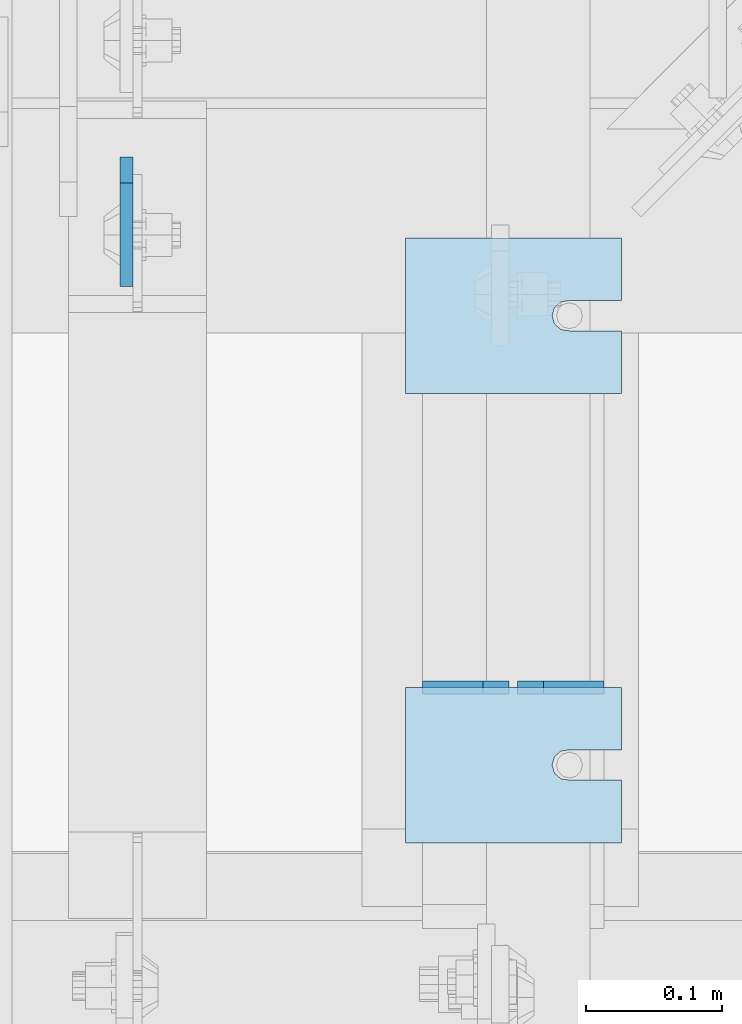
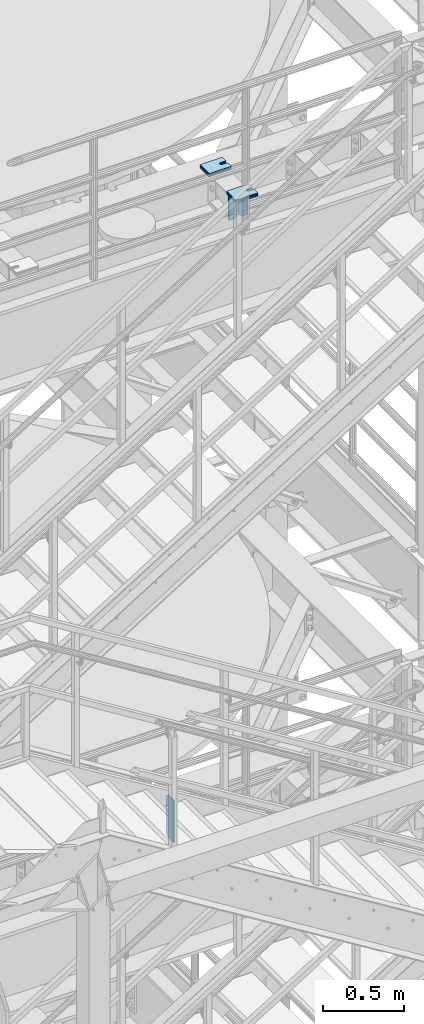
# One storey, part 1496 of 1876: 15 plates, 14 elements without a shape of their own.
"""IFC2X3 building model written with IfcOpenShell, lengths in millimetres."""

from ifc_helpers import new_model, si_unit, frame, origin_with_axes, place, context, subcontext, project, spatial, faceted_brep, material, type_object, element, aggregate, save


model = new_model("IFC2X3")

# Units and contexts
model_context = context("Model", 3, precision=1e-05, world=origin_with_axes())
body_context = subcontext(model_context, "Body", "Model", "MODEL_VIEW")
ifc_project = project(units=[si_unit("LENGTHUNIT", "METRE", prefix="MILLI"), si_unit("AREAUNIT", "SQUARE_METRE"), si_unit("VOLUMEUNIT", "CUBIC_METRE"), si_unit("MASSUNIT", "GRAM", prefix="KILO"), si_unit("TIMEUNIT", "SECOND"), si_unit("PLANEANGLEUNIT", "RADIAN"), si_unit("SOLIDANGLEUNIT", "STERADIAN"), si_unit("THERMODYNAMICTEMPERATUREUNIT", "DEGREE_CELSIUS"), si_unit("LUMINOUSINTENSITYUNIT", "LUMEN")], contexts=[model_context])

# Site, building, storey
site_placement = place(None, origin_with_axes())
site = spatial("IfcSite", under=ifc_project, at=site_placement, CompositionType="ELEMENT")
building_placement = place(site_placement, origin_with_axes())
building = spatial("IfcBuilding", under=site, at=building_placement, Name="Undefined", CompositionType="ELEMENT")
storey_placement = place(building_placement, origin_with_axes())
storey = spatial("IfcBuildingStorey", under=building, at=storey_placement, Name="Undefined", CompositionType="ELEMENT", Elevation=0.0)

# Assembly, plate
assembly_1_placement = place(storey_placement, origin_with_axes())
assembly_1 = element("IfcElementAssembly", 1, at=assembly_1_placement, inside=storey, Name="BEAM", AssemblyPlace="NOTDEFINED", PredefinedType="RIGID_FRAME")
ifc_material = material(Name="STEEL/A36")
plate_type_1 = type_object("IfcPlateType", PredefinedType="NOTDEFINED")
plate_1_placement = place(assembly_1_placement, frame((4919.66200006954, -3896.51875, 12977.8125), z_axis=(0.0, 0.0, 1.0), x_axis=(0.0, -1.0, 0.0)))
plate_1 = element("IfcPlate", 2, at=plate_1_placement, type_object=plate_type_1, material=ifc_material, Name="PLATE", context=body_context, shape_type="Brep", body=[
    faceted_brep([(0.0, -4.76249999999982, 19.0499992370605), (-1.81898940354586e-12, -4.76250000000073, 296.862499237061), (0.0, 4.76249999999982, 296.862499237061), (0.0, 4.76249999999982, 19.0499992370605), (19.0499992370605, -4.76249999999982, 315.912506103516), (19.0499992370605, 4.76249999999982, 315.912506103516), (95.25, -4.76249999999982, 315.912506103516), (95.25, 4.76249999999982, 315.912506103516), (95.25, -4.76249999999982, 0.0), (95.25, 4.76249999999982, 0.0), (19.0499992370605, -4.76249999999982, 0.0), (19.0499992370605, 4.76249999999982, 0.0)], [[[0, 1, 2, 3]], [[1, 4, 5, 2]], [[4, 6, 7, 5]], [[6, 8, 9, 7]], [[8, 10, 11, 9]], [[10, 0, 3, 11]], [[5, 7, 9, 11, 3, 2]], [[10, 8, 6, 4, 1, 0]]]),
])
aggregate(assembly_1, [plate_1])

# Assembly, plates
assembly_2_placement = place(storey_placement, origin_with_axes())
assembly_2 = element("IfcElementAssembly", 3, at=assembly_2_placement, inside=storey, Name="BEAM", AssemblyPlace="NOTDEFINED", PredefinedType="RIGID_FRAME")
plate_type_2 = type_object("IfcPlateType", PredefinedType="NOTDEFINED")
plate_2_placement = place(assembly_2_placement, frame((5270.5, -4286.24823280773, 17784.7625), z_axis=(0.0, 0.0, 1.0), x_axis=(-1.0, 0.0, 0.0)))
plate_2 = element("IfcPlate", 4, at=plate_2_placement, type_object=plate_type_2, material=ifc_material, Name="PLATE", context=body_context, shape_type="Brep", body=[
    faceted_brep([(0.0, -4.76249999999982, 0.0), (0.0, -4.76249999999982, 190.5), (0.0, 4.76249999999982, 190.5), (0.0, 4.76249999999982, 0.0), (44.4500007629395, -4.76249999999982, 190.5), (44.4500007629395, 4.76249999999982, 190.5), (63.5, -4.76249999999982, 171.450000762939), (63.5, 4.76249999999982, 171.450000762939), (63.5, -4.76249999999982, 19.0499992370605), (63.5, 4.76249999999982, 19.0499992370605), (44.4500007629395, -4.76249999999982, 0.0), (44.4500007629395, 4.76249999999982, 0.0)], [[[0, 1, 2, 3]], [[1, 4, 5, 2]], [[4, 6, 7, 5]], [[6, 8, 9, 7]], [[8, 10, 11, 9]], [[10, 0, 3, 11]], [[5, 7, 9, 11, 3, 2]], [[10, 8, 6, 4, 1, 0]]]),
])
plate_3_placement = place(assembly_2_placement, frame((5200.65, -4286.24823280773, 17784.7625), z_axis=(0.0, 0.0, 1.0), x_axis=(-1.0, 0.0, 0.0)))
plate_3 = element("IfcPlate", 5, at=plate_3_placement, type_object=plate_type_2, material=ifc_material, Name="PLATE", context=body_context, shape_type="Brep", body=[
    faceted_brep([(0.0, -4.76249999999982, 19.0499992370605), (0.0, -4.76249999999982, 171.450000762939), (0.0, 4.76249999999982, 171.450000762939), (0.0, 4.76249999999982, 19.0499992370605), (19.0499992370605, -4.76249999999982, 190.5), (19.0499992370605, 4.76249999999982, 190.5), (63.5, -4.76249999999982, 190.5), (63.5, 4.76249999999982, 190.5), (63.5, -4.76249999999982, 0.0), (63.5, 4.76249999999982, 0.0), (19.0499992370605, -4.76249999999982, 0.0), (19.0499992370605, 4.76249999999982, 0.0)], [[[0, 1, 2, 3]], [[1, 4, 5, 2]], [[4, 6, 7, 5]], [[6, 8, 9, 7]], [[8, 10, 11, 9]], [[10, 0, 3, 11]], [[5, 7, 9, 11, 3, 2]], [[10, 8, 6, 4, 1, 0]]]),
])
aggregate(assembly_2, [plate_2, plate_3])

# Assembly, plate
assembly_3_placement = place(storey_placement, origin_with_axes())
assembly_3 = element("IfcElementAssembly", 6, at=assembly_3_placement, inside=storey, Name="SHIM PLATE", AssemblyPlace="NOTDEFINED", PredefinedType="RIGID_FRAME")
plate_type_3 = type_object("IfcPlateType", PredefinedType="NOTDEFINED")
plate_4_placement = place(assembly_3_placement, frame((5124.44990071747, -4286.24823360147, 18009.3925), z_axis=(0.0, -1.0, 0.0), x_axis=(1.0, 0.0, 0.0)))
plate_4 = element("IfcPlate", 7, at=plate_4_placement, type_object=plate_type_3, material=ifc_material, Name="SHIM PLATE", context=body_context, shape_type="Brep", body=[
    faceted_brep([(158.750372340321, -0.793499999999767, 45.9159391237008), (158.750372340321, 0.793499999999767, 45.9159391237008), (120.639297339384, 0.793499999999767, 45.9151982062995), (120.639297339384, -0.793499999999767, 45.9151982062995), (114.427892427377, 0.793499999999767, 46.8593737589063), (114.427892427377, -0.793499999999767, 46.8593737589063), (109.699635978252, 0.793499999999767, 50.9965961854132), (109.699635978252, -0.793499999999767, 50.9965961854132), (107.939290344286, 0.793499999999767, 57.0276990450948), (107.939290344286, -0.793499999999767, 57.0276990450948), (109.699637497522, 0.793499999999767, 63.0588014613368), (109.699637497522, -0.793499999999767, 63.0588014613368), (114.427894988835, 0.793499999999767, 67.1960226967731), (114.427894988835, -0.793499999999767, 67.1960226967731), (120.639300138686, 0.793499999999767, 68.140196684697), (120.639300138686, -0.793499999999767, 68.140196684697), (158.750375307166, -0.793499999999767, 68.1409376021466), (158.750375307166, 0.793499999999767, 68.1409376021466), (158.750366210938, -0.793499999999767, 5.27506927028298e-11), (9.09494701772928e-13, -0.793499999999767, 0.0), (9.09494701772928e-13, 0.793499999999767, 0.0), (158.750366210938, 0.793499999999767, 5.27506927028298e-11), (1.97695580936852e-05, -0.793499999999767, 114.305328369142), (1.97695580936852e-05, 0.793499999999767, 114.305328369142), (158.750381469715, -0.793499999999767, 114.305328369159), (158.750381469715, 0.793499999999767, 114.305328369159)], [[[0, 1, 2, 3]], [[3, 2, 4, 5]], [[5, 4, 6, 7]], [[7, 6, 8, 9]], [[9, 8, 10, 11]], [[11, 10, 12, 13]], [[13, 12, 14, 15]], [[16, 15, 14, 17]], [[18, 19, 20, 21]], [[19, 22, 23, 20]], [[22, 24, 25, 23]], [[25, 24, 16, 17]], [[12, 10, 8, 6, 4, 2, 1, 21, 20, 23, 25, 17, 14]], [[18, 21, 1, 0]], [[24, 22, 19, 18, 0, 3, 5, 7, 9, 11, 13, 15, 16]]]),
])
aggregate(assembly_3, [plate_4])

assembly_4_placement = place(storey_placement, origin_with_axes())
assembly_4 = element("IfcElementAssembly", 8, at=assembly_4_placement, inside=storey, Name="SHIM PLATE", AssemblyPlace="NOTDEFINED", PredefinedType="RIGID_FRAME")
plate_5_placement = place(assembly_4_placement, frame((5124.44990071747, -3956.04803828897, 18009.3925), z_axis=(0.0, -1.0, 0.0), x_axis=(1.0, 0.0, 0.0)))
plate_5 = element("IfcPlate", 9, at=plate_5_placement, type_object=plate_type_3, material=ifc_material, Name="SHIM PLATE", context=body_context, shape_type="Brep", body=[
    faceted_brep([(158.750372340321, -0.793499999999767, 45.9159391237008), (158.750372340321, 0.793499999999767, 45.9159391237008), (120.639297339384, 0.793499999999767, 45.9151982062995), (120.639297339384, -0.793499999999767, 45.9151982062995), (114.427892427377, 0.793499999999767, 46.8593737589063), (114.427892427377, -0.793499999999767, 46.8593737589063), (109.699635978252, 0.793499999999767, 50.9965961854132), (109.699635978252, -0.793499999999767, 50.9965961854132), (107.939290344286, 0.793499999999767, 57.0276990450948), (107.939290344286, -0.793499999999767, 57.0276990450948), (109.699637497522, 0.793499999999767, 63.0588014613368), (109.699637497522, -0.793499999999767, 63.0588014613368), (114.427894988835, 0.793499999999767, 67.1960226967731), (114.427894988835, -0.793499999999767, 67.1960226967731), (120.639300138686, 0.793499999999767, 68.140196684697), (120.639300138686, -0.793499999999767, 68.140196684697), (158.750375307166, -0.793499999999767, 68.1409376021466), (158.750375307166, 0.793499999999767, 68.1409376021466), (158.750366210938, -0.793499999999767, 5.27506927028298e-11), (9.09494701772928e-13, -0.793499999999767, 0.0), (9.09494701772928e-13, 0.793499999999767, 0.0), (158.750366210938, 0.793499999999767, 5.27506927028298e-11), (1.97695580936852e-05, -0.793499999999767, 114.305328369142), (1.97695580936852e-05, 0.793499999999767, 114.305328369142), (158.750381469715, -0.793499999999767, 114.305328369159), (158.750381469715, 0.793499999999767, 114.305328369159)], [[[0, 1, 2, 3]], [[3, 2, 4, 5]], [[5, 4, 6, 7]], [[7, 6, 8, 9]], [[9, 8, 10, 11]], [[11, 10, 12, 13]], [[13, 12, 14, 15]], [[16, 15, 14, 17]], [[18, 19, 20, 21]], [[19, 22, 23, 20]], [[22, 24, 25, 23]], [[25, 24, 16, 17]], [[12, 10, 8, 6, 4, 2, 1, 21, 20, 23, 25, 17, 14]], [[18, 21, 1, 0]], [[24, 22, 19, 18, 0, 3, 5, 7, 9, 11, 13, 15, 16]]]),
])
aggregate(assembly_4, [plate_5])

assembly_5_placement = place(storey_placement, origin_with_axes())
assembly_5 = element("IfcElementAssembly", 10, at=assembly_5_placement, inside=storey, Name="SHIM PLATE", AssemblyPlace="NOTDEFINED", PredefinedType="RIGID_FRAME")
plate_type_4 = type_object("IfcPlateType", PredefinedType="NOTDEFINED")
plate_6_placement = place(assembly_5_placement, frame((5124.44990071747, -4286.24823360146, 18007.0115), z_axis=(0.0, -1.0, 0.0), x_axis=(1.0, 0.0, 0.0)))
plate_6 = element("IfcPlate", 11, at=plate_6_placement, type_object=plate_type_4, material=ifc_material, Name="SHIM PLATE", context=body_context, shape_type="Brep", body=[
    faceted_brep([(158.750372340321, -1.58750000000146, 45.9159391237008), (158.750372340321, 1.58750000000146, 45.9159391237008), (120.639297339383, 1.58750000000146, 45.9151982062995), (120.639297339383, -1.58750000000146, 45.9151982062995), (114.427892427376, 1.58750000000146, 46.8593737589063), (114.427892427376, -1.58750000000146, 46.8593737589063), (109.699635978252, 1.58750000000146, 50.9965961854132), (109.699635978252, -1.58750000000146, 50.9965961854132), (107.939290344285, 1.58750000000146, 57.0276990450948), (107.939290344285, -1.58750000000146, 57.0276990450948), (109.699637497522, 1.58750000000146, 63.0588014613368), (109.699637497522, -1.58750000000146, 63.0588014613368), (114.427894988834, 1.58750000000146, 67.1960226967731), (114.427894988834, -1.58750000000146, 67.1960226967731), (120.639300138685, 1.58750000000146, 68.140196684697), (120.639300138685, -1.58750000000146, 68.140196684697), (158.750375307166, -1.58750000000146, 68.1409376021466), (158.750375307166, 1.58750000000146, 68.1409376021466), (158.750366210938, -1.58750000000146, 5.27506927028298e-11), (9.09494701772928e-13, -1.58750000000146, 4.54747350886464e-13), (9.09494701772928e-13, 1.58750000000146, 4.54747350886464e-13), (158.750366210938, 1.58750000000146, 5.27506927028298e-11), (1.97695599126746e-05, -1.58750000000146, 114.305328369142), (1.97695599126746e-05, 1.58750000000146, 114.305328369142), (158.750381469715, -1.58750000000146, 114.305328369159), (158.750381469715, 1.58750000000146, 114.305328369159)], [[[0, 1, 2, 3]], [[3, 2, 4, 5]], [[5, 4, 6, 7]], [[7, 6, 8, 9]], [[9, 8, 10, 11]], [[11, 10, 12, 13]], [[13, 12, 14, 15]], [[16, 15, 14, 17]], [[18, 19, 20, 21]], [[19, 22, 23, 20]], [[22, 24, 25, 23]], [[25, 24, 16, 17]], [[12, 10, 8, 6, 4, 2, 1, 21, 20, 23, 25, 17, 14]], [[18, 21, 1, 0]], [[24, 22, 19, 18, 0, 3, 5, 7, 9, 11, 13, 15, 16]]]),
])
aggregate(assembly_5, [plate_6])

assembly_6_placement = place(storey_placement, origin_with_axes())
assembly_6 = element("IfcElementAssembly", 12, at=assembly_6_placement, inside=storey, Name="SHIM PLATE", AssemblyPlace="NOTDEFINED", PredefinedType="RIGID_FRAME")
plate_7_placement = place(assembly_6_placement, frame((5124.44990071747, -4286.24823360147, 18003.8365), z_axis=(0.0, -1.0, 0.0), x_axis=(1.0, 0.0, 0.0)))
plate_7 = element("IfcPlate", 13, at=plate_7_placement, type_object=plate_type_4, material=ifc_material, Name="SHIM PLATE", context=body_context, shape_type="Brep", body=[
    faceted_brep([(158.750372340321, -1.58750000000146, 45.9159391237008), (158.750372340321, 1.58750000000146, 45.9159391237008), (120.639297339383, 1.58750000000146, 45.9151982062995), (120.639297339383, -1.58750000000146, 45.9151982062995), (114.427892427376, 1.58750000000146, 46.8593737589063), (114.427892427376, -1.58750000000146, 46.8593737589063), (109.699635978252, 1.58750000000146, 50.9965961854132), (109.699635978252, -1.58750000000146, 50.9965961854132), (107.939290344285, 1.58750000000146, 57.0276990450948), (107.939290344285, -1.58750000000146, 57.0276990450948), (109.699637497522, 1.58750000000146, 63.0588014613368), (109.699637497522, -1.58750000000146, 63.0588014613368), (114.427894988834, 1.58750000000146, 67.1960226967731), (114.427894988834, -1.58750000000146, 67.1960226967731), (120.639300138685, 1.58750000000146, 68.140196684697), (120.639300138685, -1.58750000000146, 68.140196684697), (158.750375307166, -1.58750000000146, 68.1409376021466), (158.750375307166, 1.58750000000146, 68.1409376021466), (158.750366210938, -1.58750000000146, 5.27506927028298e-11), (9.09494701772928e-13, -1.58750000000146, 4.54747350886464e-13), (9.09494701772928e-13, 1.58750000000146, 4.54747350886464e-13), (158.750366210938, 1.58750000000146, 5.27506927028298e-11), (1.97695599126746e-05, -1.58750000000146, 114.305328369142), (1.97695599126746e-05, 1.58750000000146, 114.305328369142), (158.750381469715, -1.58750000000146, 114.305328369159), (158.750381469715, 1.58750000000146, 114.305328369159)], [[[0, 1, 2, 3]], [[3, 2, 4, 5]], [[5, 4, 6, 7]], [[7, 6, 8, 9]], [[9, 8, 10, 11]], [[11, 10, 12, 13]], [[13, 12, 14, 15]], [[16, 15, 14, 17]], [[18, 19, 20, 21]], [[19, 22, 23, 20]], [[22, 24, 25, 23]], [[25, 24, 16, 17]], [[12, 10, 8, 6, 4, 2, 1, 21, 20, 23, 25, 17, 14]], [[18, 21, 1, 0]], [[24, 22, 19, 18, 0, 3, 5, 7, 9, 11, 13, 15, 16]]]),
])
aggregate(assembly_6, [plate_7])

assembly_7_placement = place(storey_placement, origin_with_axes())
assembly_7 = element("IfcElementAssembly", 14, at=assembly_7_placement, inside=storey, Name="SHIM PLATE", AssemblyPlace="NOTDEFINED", PredefinedType="RIGID_FRAME")
plate_8_placement = place(assembly_7_placement, frame((5124.44990071747, -3956.04803828897, 18007.0115), z_axis=(0.0, -1.0, 0.0), x_axis=(1.0, 0.0, 0.0)))
plate_8 = element("IfcPlate", 15, at=plate_8_placement, type_object=plate_type_4, material=ifc_material, Name="SHIM PLATE", context=body_context, shape_type="Brep", body=[
    faceted_brep([(158.750372340321, -1.58750000000146, 45.9159391237008), (158.750372340321, 1.58750000000146, 45.9159391237008), (120.639297339383, 1.58750000000146, 45.9151982062995), (120.639297339383, -1.58750000000146, 45.9151982062995), (114.427892427376, 1.58750000000146, 46.8593737589063), (114.427892427376, -1.58750000000146, 46.8593737589063), (109.699635978252, 1.58750000000146, 50.9965961854132), (109.699635978252, -1.58750000000146, 50.9965961854132), (107.939290344285, 1.58750000000146, 57.0276990450948), (107.939290344285, -1.58750000000146, 57.0276990450948), (109.699637497522, 1.58750000000146, 63.0588014613368), (109.699637497522, -1.58750000000146, 63.0588014613368), (114.427894988834, 1.58750000000146, 67.1960226967731), (114.427894988834, -1.58750000000146, 67.1960226967731), (120.639300138685, 1.58750000000146, 68.140196684697), (120.639300138685, -1.58750000000146, 68.140196684697), (158.750375307166, -1.58750000000146, 68.1409376021466), (158.750375307166, 1.58750000000146, 68.1409376021466), (158.750366210938, -1.58750000000146, 5.27506927028298e-11), (9.09494701772928e-13, -1.58750000000146, 4.54747350886464e-13), (9.09494701772928e-13, 1.58750000000146, 4.54747350886464e-13), (158.750366210938, 1.58750000000146, 5.27506927028298e-11), (1.97695599126746e-05, -1.58750000000146, 114.305328369142), (1.97695599126746e-05, 1.58750000000146, 114.305328369142), (158.750381469715, -1.58750000000146, 114.305328369159), (158.750381469715, 1.58750000000146, 114.305328369159)], [[[0, 1, 2, 3]], [[3, 2, 4, 5]], [[5, 4, 6, 7]], [[7, 6, 8, 9]], [[9, 8, 10, 11]], [[11, 10, 12, 13]], [[13, 12, 14, 15]], [[16, 15, 14, 17]], [[18, 19, 20, 21]], [[19, 22, 23, 20]], [[22, 24, 25, 23]], [[25, 24, 16, 17]], [[12, 10, 8, 6, 4, 2, 1, 21, 20, 23, 25, 17, 14]], [[18, 21, 1, 0]], [[24, 22, 19, 18, 0, 3, 5, 7, 9, 11, 13, 15, 16]]]),
])
aggregate(assembly_7, [plate_8])

assembly_8_placement = place(storey_placement, origin_with_axes())
assembly_8 = element("IfcElementAssembly", 16, at=assembly_8_placement, inside=storey, Name="SHIM PLATE", AssemblyPlace="NOTDEFINED", PredefinedType="RIGID_FRAME")
plate_9_placement = place(assembly_8_placement, frame((5124.44990071747, -3956.04803828897, 18003.8365), z_axis=(0.0, -1.0, 0.0), x_axis=(1.0, 0.0, 0.0)))
plate_9 = element("IfcPlate", 17, at=plate_9_placement, type_object=plate_type_4, material=ifc_material, Name="SHIM PLATE", context=body_context, shape_type="Brep", body=[
    faceted_brep([(158.750372340321, -1.58750000000146, 45.9159391237008), (158.750372340321, 1.58750000000146, 45.9159391237008), (120.639297339383, 1.58750000000146, 45.9151982062995), (120.639297339383, -1.58750000000146, 45.9151982062995), (114.427892427376, 1.58750000000146, 46.8593737589063), (114.427892427376, -1.58750000000146, 46.8593737589063), (109.699635978252, 1.58750000000146, 50.9965961854132), (109.699635978252, -1.58750000000146, 50.9965961854132), (107.939290344285, 1.58750000000146, 57.0276990450948), (107.939290344285, -1.58750000000146, 57.0276990450948), (109.699637497522, 1.58750000000146, 63.0588014613368), (109.699637497522, -1.58750000000146, 63.0588014613368), (114.427894988834, 1.58750000000146, 67.1960226967731), (114.427894988834, -1.58750000000146, 67.1960226967731), (120.639300138685, 1.58750000000146, 68.140196684697), (120.639300138685, -1.58750000000146, 68.140196684697), (158.750375307166, -1.58750000000146, 68.1409376021466), (158.750375307166, 1.58750000000146, 68.1409376021466), (158.750366210938, -1.58750000000146, 5.27506927028298e-11), (9.09494701772928e-13, -1.58750000000146, 4.54747350886464e-13), (9.09494701772928e-13, 1.58750000000146, 4.54747350886464e-13), (158.750366210938, 1.58750000000146, 5.27506927028298e-11), (1.97695599126746e-05, -1.58750000000146, 114.305328369142), (1.97695599126746e-05, 1.58750000000146, 114.305328369142), (158.750381469715, -1.58750000000146, 114.305328369159), (158.750381469715, 1.58750000000146, 114.305328369159)], [[[0, 1, 2, 3]], [[3, 2, 4, 5]], [[5, 4, 6, 7]], [[7, 6, 8, 9]], [[9, 8, 10, 11]], [[11, 10, 12, 13]], [[13, 12, 14, 15]], [[16, 15, 14, 17]], [[18, 19, 20, 21]], [[19, 22, 23, 20]], [[22, 24, 25, 23]], [[25, 24, 16, 17]], [[12, 10, 8, 6, 4, 2, 1, 21, 20, 23, 25, 17, 14]], [[18, 21, 1, 0]], [[24, 22, 19, 18, 0, 3, 5, 7, 9, 11, 13, 15, 16]]]),
])
aggregate(assembly_8, [plate_9])

assembly_9_placement = place(storey_placement, origin_with_axes())
assembly_9 = element("IfcElementAssembly", 18, at=assembly_9_placement, inside=storey, Name="SHIM PLATE", AssemblyPlace="NOTDEFINED", PredefinedType="RIGID_FRAME")
plate_type_5 = type_object("IfcPlateType", PredefinedType="NOTDEFINED")
plate_10_placement = place(assembly_9_placement, frame((5124.44990071747, -4286.24823360147, 17999.868), z_axis=(0.0, -1.0, 0.0), x_axis=(1.0, 0.0, 0.0)))
plate_10 = element("IfcPlate", 19, at=plate_10_placement, type_object=plate_type_5, material=ifc_material, Name="SHIM PLATE", context=body_context, shape_type="Brep", body=[
    faceted_brep([(158.750372340321, -2.38100000000122, 45.9159391237008), (158.750372340321, 2.38100000000122, 45.9159391237008), (120.639297339384, 2.38100000000122, 45.9151982062995), (120.639297339384, -2.38100000000122, 45.9151982062995), (114.427892427377, 2.38100000000122, 46.8593737589063), (114.427892427377, -2.38100000000122, 46.8593737589063), (109.699635978252, 2.38100000000122, 50.9965961854132), (109.699635978252, -2.38100000000122, 50.9965961854132), (107.939290344286, 2.38100000000122, 57.0276990450948), (107.939290344286, -2.38100000000122, 57.0276990450948), (109.699637497522, 2.38100000000122, 63.0588014613368), (109.699637497522, -2.38100000000122, 63.0588014613368), (114.427894988835, 2.38100000000122, 67.1960226967731), (114.427894988835, -2.38100000000122, 67.1960226967731), (120.639300138686, 2.38100000000122, 68.140196684697), (120.639300138686, -2.38100000000122, 68.140196684697), (158.750375307166, -2.38100000000122, 68.1409376021466), (158.750375307166, 2.38100000000122, 68.1409376021466), (158.750366210938, -2.38100000000122, 5.27506927028298e-11), (0.0, -2.38100000000122, 4.54747350886464e-13), (0.0, 2.38100000000122, 4.54747350886464e-13), (158.750366210938, 2.38100000000122, 5.27506927028298e-11), (1.9769561731664e-05, -2.38100000000122, 114.305328369142), (1.9769561731664e-05, 2.38100000000122, 114.305328369142), (158.750381469715, -2.38100000000122, 114.305328369159), (158.750381469715, 2.38100000000122, 114.305328369159)], [[[0, 1, 2, 3]], [[3, 2, 4, 5]], [[5, 4, 6, 7]], [[7, 6, 8, 9]], [[9, 8, 10, 11]], [[11, 10, 12, 13]], [[13, 12, 14, 15]], [[16, 15, 14, 17]], [[18, 19, 20, 21]], [[19, 22, 23, 20]], [[22, 24, 25, 23]], [[25, 24, 16, 17]], [[12, 10, 8, 6, 4, 2, 1, 21, 20, 23, 25, 17, 14]], [[18, 21, 1, 0]], [[24, 22, 19, 18, 0, 3, 5, 7, 9, 11, 13, 15, 16]]]),
])
aggregate(assembly_9, [plate_10])

assembly_10_placement = place(storey_placement, origin_with_axes())
assembly_10 = element("IfcElementAssembly", 20, at=assembly_10_placement, inside=storey, Name="SHIM PLATE", AssemblyPlace="NOTDEFINED", PredefinedType="RIGID_FRAME")
plate_11_placement = place(assembly_10_placement, frame((5124.44990071747, -4286.24823360146, 17995.106), z_axis=(0.0, -1.0, 0.0), x_axis=(1.0, 0.0, 0.0)))
plate_11 = element("IfcPlate", 21, at=plate_11_placement, type_object=plate_type_5, material=ifc_material, Name="SHIM PLATE", context=body_context, shape_type="Brep", body=[
    faceted_brep([(158.750372340321, -2.38100000000122, 45.9159391237008), (158.750372340321, 2.38100000000122, 45.9159391237008), (120.639297339384, 2.38100000000122, 45.9151982062995), (120.639297339384, -2.38100000000122, 45.9151982062995), (114.427892427377, 2.38100000000122, 46.8593737589063), (114.427892427377, -2.38100000000122, 46.8593737589063), (109.699635978252, 2.38100000000122, 50.9965961854132), (109.699635978252, -2.38100000000122, 50.9965961854132), (107.939290344286, 2.38100000000122, 57.0276990450948), (107.939290344286, -2.38100000000122, 57.0276990450948), (109.699637497522, 2.38100000000122, 63.0588014613368), (109.699637497522, -2.38100000000122, 63.0588014613368), (114.427894988835, 2.38100000000122, 67.1960226967731), (114.427894988835, -2.38100000000122, 67.1960226967731), (120.639300138686, 2.38100000000122, 68.140196684697), (120.639300138686, -2.38100000000122, 68.140196684697), (158.750375307166, -2.38100000000122, 68.1409376021466), (158.750375307166, 2.38100000000122, 68.1409376021466), (158.750366210938, -2.38100000000122, 5.27506927028298e-11), (0.0, -2.38100000000122, 4.54747350886464e-13), (0.0, 2.38100000000122, 4.54747350886464e-13), (158.750366210938, 2.38100000000122, 5.27506927028298e-11), (1.9769561731664e-05, -2.38100000000122, 114.305328369142), (1.9769561731664e-05, 2.38100000000122, 114.305328369142), (158.750381469715, -2.38100000000122, 114.305328369159), (158.750381469715, 2.38100000000122, 114.305328369159)], [[[0, 1, 2, 3]], [[3, 2, 4, 5]], [[5, 4, 6, 7]], [[7, 6, 8, 9]], [[9, 8, 10, 11]], [[11, 10, 12, 13]], [[13, 12, 14, 15]], [[16, 15, 14, 17]], [[18, 19, 20, 21]], [[19, 22, 23, 20]], [[22, 24, 25, 23]], [[25, 24, 16, 17]], [[12, 10, 8, 6, 4, 2, 1, 21, 20, 23, 25, 17, 14]], [[18, 21, 1, 0]], [[24, 22, 19, 18, 0, 3, 5, 7, 9, 11, 13, 15, 16]]]),
])
aggregate(assembly_10, [plate_11])

assembly_11_placement = place(storey_placement, origin_with_axes())
assembly_11 = element("IfcElementAssembly", 22, at=assembly_11_placement, inside=storey, Name="SHIM PLATE", AssemblyPlace="NOTDEFINED", PredefinedType="RIGID_FRAME")
plate_12_placement = place(assembly_11_placement, frame((5124.44990071747, -3956.04803828897, 17999.868), z_axis=(0.0, -1.0, 0.0), x_axis=(1.0, 0.0, 0.0)))
plate_12 = element("IfcPlate", 23, at=plate_12_placement, type_object=plate_type_5, material=ifc_material, Name="SHIM PLATE", context=body_context, shape_type="Brep", body=[
    faceted_brep([(158.750372340321, -2.38100000000122, 45.9159391237008), (158.750372340321, 2.38100000000122, 45.9159391237008), (120.639297339384, 2.38100000000122, 45.9151982062995), (120.639297339384, -2.38100000000122, 45.9151982062995), (114.427892427377, 2.38100000000122, 46.8593737589063), (114.427892427377, -2.38100000000122, 46.8593737589063), (109.699635978252, 2.38100000000122, 50.9965961854132), (109.699635978252, -2.38100000000122, 50.9965961854132), (107.939290344286, 2.38100000000122, 57.0276990450948), (107.939290344286, -2.38100000000122, 57.0276990450948), (109.699637497522, 2.38100000000122, 63.0588014613368), (109.699637497522, -2.38100000000122, 63.0588014613368), (114.427894988835, 2.38100000000122, 67.1960226967731), (114.427894988835, -2.38100000000122, 67.1960226967731), (120.639300138686, 2.38100000000122, 68.140196684697), (120.639300138686, -2.38100000000122, 68.140196684697), (158.750375307166, -2.38100000000122, 68.1409376021466), (158.750375307166, 2.38100000000122, 68.1409376021466), (158.750366210938, -2.38100000000122, 5.27506927028298e-11), (0.0, -2.38100000000122, 4.54747350886464e-13), (0.0, 2.38100000000122, 4.54747350886464e-13), (158.750366210938, 2.38100000000122, 5.27506927028298e-11), (1.9769561731664e-05, -2.38100000000122, 114.305328369142), (1.9769561731664e-05, 2.38100000000122, 114.305328369142), (158.750381469715, -2.38100000000122, 114.305328369159), (158.750381469715, 2.38100000000122, 114.305328369159)], [[[0, 1, 2, 3]], [[3, 2, 4, 5]], [[5, 4, 6, 7]], [[7, 6, 8, 9]], [[9, 8, 10, 11]], [[11, 10, 12, 13]], [[13, 12, 14, 15]], [[16, 15, 14, 17]], [[18, 19, 20, 21]], [[19, 22, 23, 20]], [[22, 24, 25, 23]], [[25, 24, 16, 17]], [[12, 10, 8, 6, 4, 2, 1, 21, 20, 23, 25, 17, 14]], [[18, 21, 1, 0]], [[24, 22, 19, 18, 0, 3, 5, 7, 9, 11, 13, 15, 16]]]),
])
aggregate(assembly_11, [plate_12])

assembly_12_placement = place(storey_placement, origin_with_axes())
assembly_12 = element("IfcElementAssembly", 24, at=assembly_12_placement, inside=storey, Name="SHIM PLATE", AssemblyPlace="NOTDEFINED", PredefinedType="RIGID_FRAME")
plate_13_placement = place(assembly_12_placement, frame((5124.44990071747, -3956.04803828897, 17995.106), z_axis=(0.0, -1.0, 0.0), x_axis=(1.0, 0.0, 0.0)))
plate_13 = element("IfcPlate", 25, at=plate_13_placement, type_object=plate_type_5, material=ifc_material, Name="SHIM PLATE", context=body_context, shape_type="Brep", body=[
    faceted_brep([(158.750372340321, -2.38100000000122, 45.9159391237008), (158.750372340321, 2.38100000000122, 45.9159391237008), (120.639297339384, 2.38100000000122, 45.9151982062995), (120.639297339384, -2.38100000000122, 45.9151982062995), (114.427892427377, 2.38100000000122, 46.8593737589063), (114.427892427377, -2.38100000000122, 46.8593737589063), (109.699635978252, 2.38100000000122, 50.9965961854132), (109.699635978252, -2.38100000000122, 50.9965961854132), (107.939290344286, 2.38100000000122, 57.0276990450948), (107.939290344286, -2.38100000000122, 57.0276990450948), (109.699637497522, 2.38100000000122, 63.0588014613368), (109.699637497522, -2.38100000000122, 63.0588014613368), (114.427894988835, 2.38100000000122, 67.1960226967731), (114.427894988835, -2.38100000000122, 67.1960226967731), (120.639300138686, 2.38100000000122, 68.140196684697), (120.639300138686, -2.38100000000122, 68.140196684697), (158.750375307166, -2.38100000000122, 68.1409376021466), (158.750375307166, 2.38100000000122, 68.1409376021466), (158.750366210938, -2.38100000000122, 5.27506927028298e-11), (0.0, -2.38100000000122, 4.54747350886464e-13), (0.0, 2.38100000000122, 4.54747350886464e-13), (158.750366210938, 2.38100000000122, 5.27506927028298e-11), (1.9769561731664e-05, -2.38100000000122, 114.305328369142), (1.9769561731664e-05, 2.38100000000122, 114.305328369142), (158.750381469715, -2.38100000000122, 114.305328369159), (158.750381469715, 2.38100000000122, 114.305328369159)], [[[0, 1, 2, 3]], [[3, 2, 4, 5]], [[5, 4, 6, 7]], [[7, 6, 8, 9]], [[9, 8, 10, 11]], [[11, 10, 12, 13]], [[13, 12, 14, 15]], [[16, 15, 14, 17]], [[18, 19, 20, 21]], [[19, 22, 23, 20]], [[22, 24, 25, 23]], [[25, 24, 16, 17]], [[12, 10, 8, 6, 4, 2, 1, 21, 20, 23, 25, 17, 14]], [[18, 21, 1, 0]], [[24, 22, 19, 18, 0, 3, 5, 7, 9, 11, 13, 15, 16]]]),
])
aggregate(assembly_12, [plate_13])

assembly_13_placement = place(storey_placement, origin_with_axes())
assembly_13 = element("IfcElementAssembly", 26, at=assembly_13_placement, inside=storey, Name="SHIM PLATE", AssemblyPlace="NOTDEFINED", PredefinedType="RIGID_FRAME")
plate_type_6 = type_object("IfcPlateType", PredefinedType="NOTDEFINED")
plate_14_placement = place(assembly_13_placement, frame((5124.44990071747, -4286.24823360146, 17987.9625), z_axis=(0.0, -1.0, 0.0), x_axis=(1.0, 0.0, 0.0)))
plate_14 = element("IfcPlate", 27, at=plate_14_placement, type_object=plate_type_6, material=ifc_material, Name="SHIM PLATE", context=body_context, shape_type="Brep", body=[
    faceted_brep([(158.750372340321, -4.76250000000073, 45.9159391237008), (158.750372340321, 4.76250000000073, 45.9159391237008), (120.639297339384, 4.76250000000073, 45.9151982062995), (120.639297339384, -4.76250000000073, 45.9151982062995), (114.427892427377, 4.76250000000073, 46.8593737589063), (114.427892427377, -4.76250000000073, 46.8593737589063), (109.699635978252, 4.76250000000073, 50.9965961854132), (109.699635978252, -4.76250000000073, 50.9965961854132), (107.939290344286, 4.76250000000073, 57.0276990450948), (107.939290344286, -4.76250000000073, 57.0276990450948), (109.699637497522, 4.76250000000073, 63.0588014613368), (109.699637497522, -4.76250000000073, 63.0588014613368), (114.427894988835, 4.76250000000073, 67.1960226967731), (114.427894988835, -4.76250000000073, 67.1960226967731), (120.639300138686, 4.76250000000073, 68.140196684697), (120.639300138686, -4.76250000000073, 68.140196684697), (158.750375307166, -4.76250000000073, 68.1409376021466), (158.750375307166, 4.76250000000073, 68.1409376021466), (158.750366210938, -4.76250000000073, 5.27506927028298e-11), (0.0, -4.76249999999982, 0.0), (0.0, 4.76249999999982, 0.0), (158.750366210938, 4.76250000000073, 5.27506927028298e-11), (1.97695635506534e-05, -4.76250000000073, 114.305328369142), (1.97695635506534e-05, 4.76250000000073, 114.305328369142), (158.750381469715, -4.76250000000073, 114.305328369159), (158.750381469715, 4.76250000000073, 114.305328369159)], [[[0, 1, 2, 3]], [[3, 2, 4, 5]], [[5, 4, 6, 7]], [[7, 6, 8, 9]], [[9, 8, 10, 11]], [[11, 10, 12, 13]], [[13, 12, 14, 15]], [[16, 15, 14, 17]], [[18, 19, 20, 21]], [[19, 22, 23, 20]], [[22, 24, 25, 23]], [[25, 24, 16, 17]], [[12, 10, 8, 6, 4, 2, 1, 21, 20, 23, 25, 17, 14]], [[18, 21, 1, 0]], [[24, 22, 19, 18, 0, 3, 5, 7, 9, 11, 13, 15, 16]]]),
])
aggregate(assembly_13, [plate_14])

assembly_14_placement = place(storey_placement, origin_with_axes())
assembly_14 = element("IfcElementAssembly", 28, at=assembly_14_placement, inside=storey, Name="SHIM PLATE", AssemblyPlace="NOTDEFINED", PredefinedType="RIGID_FRAME")
plate_15_placement = place(assembly_14_placement, frame((5124.44990071747, -3956.04803828897, 17987.9625), z_axis=(0.0, -1.0, 0.0), x_axis=(1.0, 0.0, 0.0)))
plate_15 = element("IfcPlate", 29, at=plate_15_placement, type_object=plate_type_6, material=ifc_material, Name="SHIM PLATE", context=body_context, shape_type="Brep", body=[
    faceted_brep([(158.750372340321, -4.76250000000073, 45.9159391237008), (158.750372340321, 4.76250000000073, 45.9159391237008), (120.639297339384, 4.76250000000073, 45.9151982062995), (120.639297339384, -4.76250000000073, 45.9151982062995), (114.427892427377, 4.76250000000073, 46.8593737589063), (114.427892427377, -4.76250000000073, 46.8593737589063), (109.699635978252, 4.76250000000073, 50.9965961854132), (109.699635978252, -4.76250000000073, 50.9965961854132), (107.939290344286, 4.76250000000073, 57.0276990450948), (107.939290344286, -4.76250000000073, 57.0276990450948), (109.699637497522, 4.76250000000073, 63.0588014613368), (109.699637497522, -4.76250000000073, 63.0588014613368), (114.427894988835, 4.76250000000073, 67.1960226967731), (114.427894988835, -4.76250000000073, 67.1960226967731), (120.639300138686, 4.76250000000073, 68.140196684697), (120.639300138686, -4.76250000000073, 68.140196684697), (158.750375307166, -4.76250000000073, 68.1409376021466), (158.750375307166, 4.76250000000073, 68.1409376021466), (158.750366210938, -4.76250000000073, 5.27506927028298e-11), (0.0, -4.76249999999982, 0.0), (0.0, 4.76249999999982, 0.0), (158.750366210938, 4.76250000000073, 5.27506927028298e-11), (1.97695635506534e-05, -4.76250000000073, 114.305328369142), (1.97695635506534e-05, 4.76250000000073, 114.305328369142), (158.750381469715, -4.76250000000073, 114.305328369159), (158.750381469715, 4.76250000000073, 114.305328369159)], [[[0, 1, 2, 3]], [[3, 2, 4, 5]], [[5, 4, 6, 7]], [[7, 6, 8, 9]], [[9, 8, 10, 11]], [[11, 10, 12, 13]], [[13, 12, 14, 15]], [[16, 15, 14, 17]], [[18, 19, 20, 21]], [[19, 22, 23, 20]], [[22, 24, 25, 23]], [[25, 24, 16, 17]], [[12, 10, 8, 6, 4, 2, 1, 21, 20, 23, 25, 17, 14]], [[18, 21, 1, 0]], [[24, 22, 19, 18, 0, 3, 5, 7, 9, 11, 13, 15, 16]]]),
])
aggregate(assembly_14, [plate_15])

save(model, "model.ifc")
